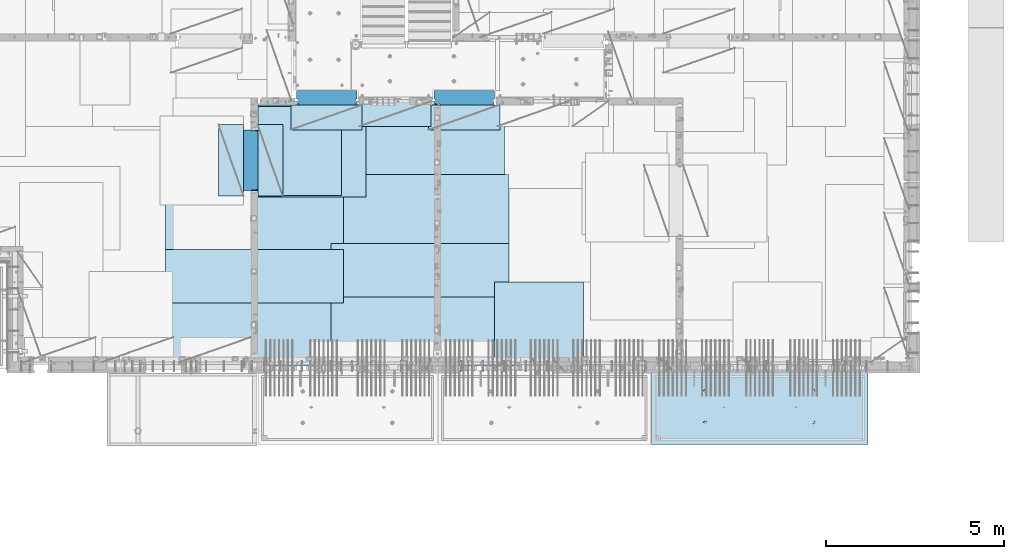
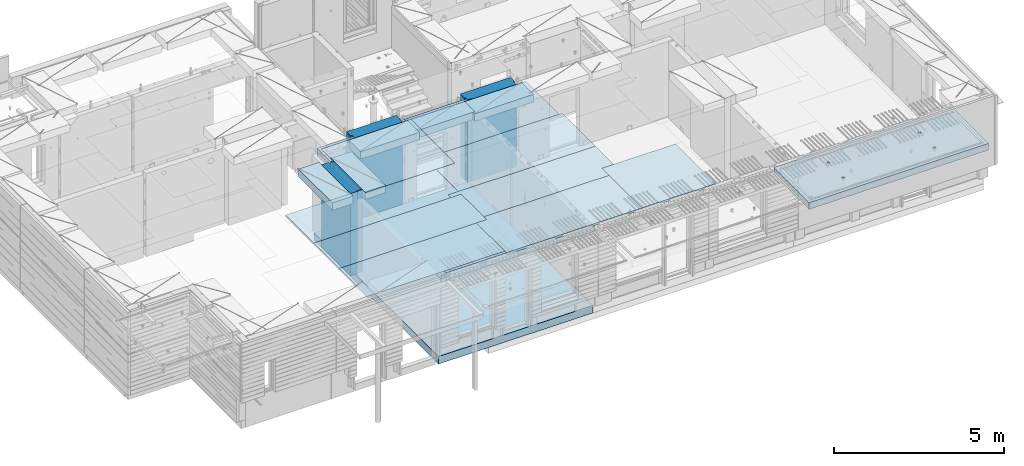
# One storey, part 182 of 325: 18 plates, 3 slabs, 20 elements without a shape of their own.
"""IFC2X3 building model written with IfcOpenShell, lengths in millimetres."""

import ifcopenshell
import ifcopenshell.guid

model = None  # the IFC model being written
_history = None  # IfcOwnerHistory: only IFC2X3 demands one
_inside = {}  # id of a spatial element -> (the spatial element, [elements in it])
_under = {}  # id of a project, library or spatial element -> (it, [spatial elements below it])
_declared = {}  # id of a project -> (the project, [libraries it declares])
_typed = {}  # id of a type object -> (the type object, [elements of that type])
_made_of = {}  # id of a material, layer set ... -> (it, [elements and type objects made of it])


def new_model(schema):
    """Start an empty IFC model of exactly this schema.

    Asked for "IFC4X3", IfcOpenShell would pick the latest addendum, in which some entities
    have other attributes; the version numbers below select the first issue.
    IFC2X3 requires an IfcOwnerHistory on every rooted entity: one is made here for all.
    """
    global model, _history
    if schema == "IFC4X3":
        model = ifcopenshell.file(schema_version=(4, 3, 0, 0))
    else:
        model = ifcopenshell.file(schema=schema)
    _inside.clear()
    _under.clear()
    _declared.clear()
    _typed.clear()
    _made_of.clear()
    _history = None
    if model.schema == "IFC2X3":
        org = make("IfcOrganization", Name="unknown")
        user = make(
            "IfcPersonAndOrganization",
            ThePerson=make("IfcPerson", FamilyName="unknown"),
            TheOrganization=org,
        )
        app = make(
            "IfcApplication",
            ApplicationDeveloper=org,
            Version="unknown",
            ApplicationFullName="unknown",
            ApplicationIdentifier="unknown",
        )
        _history = make(
            "IfcOwnerHistory",
            OwningUser=user,
            OwningApplication=app,
            ChangeAction="ADDED",
            CreationDate=0,
        )
    return model


def make(cls, **values):
    """One entity of the class cls with the attributes given. An attribute that is None is left unset."""
    return model.create_entity(
        cls, **{name: value for name, value in values.items() if value is not None}
    )


def rooted(cls, **values):
    """An entity with a GlobalId (a new one), such as an element, a storey or a relation."""
    return make(cls, GlobalId=ifcopenshell.guid.new(), OwnerHistory=_history, **values)


def si_unit(unit_type, name, prefix=None):
    """IfcSIUnit, for example si_unit("LENGTHUNIT", "METRE", prefix="MILLI")."""
    return make("IfcSIUnit", UnitType=unit_type, Prefix=prefix, Name=name)


def assignment(units):
    """IfcUnitAssignment: the units of a project."""
    return None if units is None else make("IfcUnitAssignment", Units=units)


def point(xyz):
    """IfcCartesianPoint."""
    return None if xyz is None else make("IfcCartesianPoint", Coordinates=xyz)


def direction(xyz):
    """IfcDirection."""
    return None if xyz is None else make("IfcDirection", DirectionRatios=xyz)


def frame(location, z_axis=None, x_axis=None):
    """IfcAxis2Placement3D, a coordinate frame: its origin and axes. An axis left out is left unset."""
    return make(
        "IfcAxis2Placement3D",
        Location=point(location),
        Axis=direction(z_axis),
        RefDirection=direction(x_axis),
    )


def origin_with_axes():
    """The frame at (0, 0, 0) with the z axis (0, 0, 1) and the x axis (1, 0, 0) written out."""
    return frame((0.0, 0.0, 0.0), z_axis=(0.0, 0.0, 1.0), x_axis=(1.0, 0.0, 0.0))


def place(relative_to, where):
    """IfcLocalPlacement: puts the frame where relative to a parent placement (None: the world)."""
    return make(
        "IfcLocalPlacement", PlacementRelTo=relative_to, RelativePlacement=where
    )


def context(
    kind, dimensions, precision=None, world=None, true_north=None, identifier=None
):
    """IfcGeometricRepresentationContext, for example the 3D "Model" context."""
    return make(
        "IfcGeometricRepresentationContext",
        ContextIdentifier=identifier,
        ContextType=kind,
        CoordinateSpaceDimension=dimensions,
        Precision=precision,
        WorldCoordinateSystem=world,
        TrueNorth=true_north,
    )


def subcontext(parent, identifier, kind, view, scale=None):
    """IfcGeometricRepresentationSubContext, for example "Body" below "Model"."""
    return make(
        "IfcGeometricRepresentationSubContext",
        ContextIdentifier=identifier,
        ContextType=kind,
        ParentContext=parent,
        TargetScale=scale,
        TargetView=view,
    )


def project(units=None, contexts=None):
    """IfcProject with its units and contexts."""
    return rooted(
        "IfcProject",
        Name="project",
        RepresentationContexts=contexts,
        UnitsInContext=assignment(units),
    )


def spatial(cls, under=None, at=None, **own):
    """A site, building, storey or space (cls), placed at a placement, below another one or the project."""
    s = rooted(cls, ObjectPlacement=at, **own)
    if under is not None:
        _under.setdefault(under.id(), (under, []))[1].append(s)
    return s


def faces_of(points, faces, orient=None, outer=None):
    """IfcFace entities. A face is a list of loops; a loop is a list of indices into points, from 0.

    orient and outer hold one flag for each loop. By default every Orientation is true, the
    first loop of a face is its IfcFaceOuterBound and the others are IfcFaceBound.
    """
    made = []
    for i, loops in enumerate(faces):
        bounds = []
        for j, loop in enumerate(loops):
            is_outer = j == 0 if outer is None else outer[i][j]
            bounds.append(
                make(
                    "IfcFaceOuterBound" if is_outer else "IfcFaceBound",
                    Bound=make("IfcPolyLoop", Polygon=[points[k] for k in loop]),
                    Orientation=True if orient is None else orient[i][j],
                )
            )
        made.append(make("IfcFace", Bounds=bounds))
    return made


def faceted_brep(points, faces, orient=None, outer=None, voids=None):
    """IfcFacetedBrep: a solid bounded by flat faces; with voids (closed shells), ...WithVoids."""
    shared = [point(p) for p in points]
    hull = make("IfcClosedShell", CfsFaces=faces_of(shared, faces, orient, outer))
    if voids is None:
        return make("IfcFacetedBrep", Outer=hull)
    return make(
        "IfcFacetedBrepWithVoids",
        Outer=hull,
        Voids=[
            make(cls, CfsFaces=faces_of(shared, fs, o, b)) for cls, fs, o, b in voids
        ],
    )


def shape(context_of_items, identifier, shape_type, items):
    """IfcShapeRepresentation: the items that make up one representation, for example the "Body"."""
    return make(
        "IfcShapeRepresentation",
        ContextOfItems=context_of_items,
        RepresentationIdentifier=identifier,
        RepresentationType=shape_type,
        Items=items,
    )


def material(Name=None, Category=None):
    """IfcMaterial."""
    return make("IfcMaterial", Name=Name, Category=Category)


def made_of(thing, what):
    """Note that an element or type object is made of a material, layer set ...; save() writes the relation."""
    if what is not None:
        _made_of.setdefault(what.id(), (what, []))[1].append(thing)
    return thing


def type_object(cls, material=None, **own):
    """A type object (cls), such as IfcWallType, which elements share."""
    return made_of(rooted(cls, **own), material)


def element(
    cls,
    number,
    at=None,
    inside=None,
    cuts=None,
    type_object=None,
    material=None,
    context=None,
    identifier="Body",
    shape_type=None,
    held_by="IfcProductDefinitionShape",
    body=None,
    shapes=None,
    **own,
):
    """One element of the class cls, such as IfcWall. Its Tag is "e" and its number.

    at: its placement. inside: the storey or other place that contains it. cuts: it is an
    opening in that element (IfcRelVoidsElement). A single representation is given by context,
    identifier, shape_type and body (its items); several are given by shapes. held_by: the class
    of the entity that holds the representations. save() writes the other relations.
    """
    e = rooted(cls, Tag="e%d" % number, ObjectPlacement=at, **own)
    if body is not None:
        shapes = [shape(context, identifier, shape_type, body)]
    if shapes is not None:
        e.Representation = make(held_by, Representations=shapes)
    if inside is not None:
        _inside.setdefault(inside.id(), (inside, []))[1].append(e)
    if cuts is not None:
        rooted(
            "IfcRelVoidsElement", RelatingBuildingElement=cuts, RelatedOpeningElement=e
        )
    if type_object is not None:
        _typed.setdefault(type_object.id(), (type_object, []))[1].append(e)
    return made_of(e, material)


def aggregate(whole, parts):
    """IfcRelAggregates: a whole, such as a stair, and the parts it consists of."""
    return rooted("IfcRelAggregates", RelatingObject=whole, RelatedObjects=parts)


def save(model, path):
    """Write the relations noted so far, then the file.

    IfcRelAggregates (storeys below a building ...), IfcRelContainedInSpatialStructure (elements
    in a storey), IfcRelDefinesByType, IfcRelAssociatesMaterial and IfcRelDeclares: one each for
    every whole, place, type object, material and project.
    """
    for whole, parts in _under.values():
        aggregate(whole, parts)
    for where, things in _inside.values():
        rooted(
            "IfcRelContainedInSpatialStructure",
            RelatedElements=things,
            RelatingStructure=where,
        )
    for kind, things in _typed.values():
        rooted("IfcRelDefinesByType", RelatedObjects=things, RelatingType=kind)
    for what, things in _made_of.values():
        rooted("IfcRelAssociatesMaterial", RelatedObjects=things, RelatingMaterial=what)
    for by, libraries in _declared.values():
        rooted("IfcRelDeclares", RelatingContext=by, RelatedDefinitions=libraries)
    model.write(path)


model = new_model("IFC2X3")

# Units and contexts
model_context = context("Model", 3, precision=1e-05, world=origin_with_axes())
body_context = subcontext(model_context, "Body", "Model", "MODEL_VIEW")
ifc_project = project(units=[si_unit("LENGTHUNIT", "METRE", prefix="MILLI"), si_unit("AREAUNIT", "SQUARE_METRE"), si_unit("VOLUMEUNIT", "CUBIC_METRE"), si_unit("MASSUNIT", "GRAM", prefix="KILO"), si_unit("TIMEUNIT", "SECOND"), si_unit("PLANEANGLEUNIT", "RADIAN"), si_unit("SOLIDANGLEUNIT", "STERADIAN"), si_unit("THERMODYNAMICTEMPERATUREUNIT", "DEGREE_CELSIUS"), si_unit("LUMINOUSINTENSITYUNIT", "LUMEN")], contexts=[model_context])

# Site, building, storey
site_placement = place(None, origin_with_axes())
site = spatial("IfcSite", under=ifc_project, at=site_placement, CompositionType="ELEMENT")
building_placement = place(site_placement, origin_with_axes())
building = spatial("IfcBuilding", under=site, at=building_placement, CompositionType="ELEMENT")
storey_placement = place(building_placement, origin_with_axes())
storey = spatial("IfcBuildingStorey", under=building, at=storey_placement, Name="1", CompositionType="ELEMENT", Elevation=0.0)

# Assembly, slab
assembly_1_placement = place(storey_placement, origin_with_axes())
assembly_1 = element("IfcElementAssembly", 1, at=assembly_1_placement, inside=storey, AssemblyPlace="NOTDEFINED", PredefinedType="REINFORCEMENT_UNIT")
ifc_material_1 = material(Name="CONCRETE/C30/37")
slab_type_1 = type_object("IfcSlabType", PredefinedType="NOTDEFINED")
slab_1_placement = place(assembly_1_placement, frame((21810.0, 15180.0, 81595.0), z_axis=(0.0, -1.0, 0.0), x_axis=(-1.0, 3.00000001838171e-08, 0.0)))
slab_1 = element("IfcSlab", 2, at=slab_1_placement, type_object=slab_type_1, material=ifc_material_1, PredefinedType="FLOOR", context=body_context, shape_type="Brep", body=[
    faceted_brep([(1.81898940354586e-12, -135.0, 1.81898940354586e-12), (0.0, -135.0, 7330.0), (0.0, 135.0, 7330.0), (1.81898940354586e-12, 135.0, 1.81898940354586e-12), (5055.0, -135.0, 7330.0), (5055.0, 135.0, 7330.0), (5250.0, -135.0, 7330.0), (5250.0, 135.0, 7330.0), (5250.0, -135.0, 0.0), (5250.0, 135.0, 0.0)], [[[0, 1, 2, 3]], [[1, 4, 5, 2]], [[4, 6, 7, 5]], [[6, 8, 9, 7]], [[8, 0, 3, 9]], [[5, 7, 9, 3, 2]], [[8, 6, 4, 1, 0]]]),
])
aggregate(assembly_1, [slab_1])

assembly_2_placement = place(storey_placement, origin_with_axes())
assembly_2 = element("IfcElementAssembly", 3, at=assembly_2_placement, inside=storey, AssemblyPlace="NOTDEFINED", PredefinedType="REINFORCEMENT_UNIT")
ifc_material_2 = material(Name="CONCRETE/C35/45")
slab_type_2 = type_object("IfcSlabType", PredefinedType="NOTDEFINED")
slab_2_placement = place(assembly_2_placement, frame((33909.9998568133, 7629.99655735226, 84590.0), z_axis=(-1.11800000013248e-06, -0.999999999999375, 0.0), x_axis=(-0.999999999999093, 1.34699999998405e-06, 0.0)))
slab_2 = element("IfcSlab", 4, at=slab_2_placement, type_object=slab_type_2, material=ifc_material_2, PredefinedType="FLOOR", context=body_context, shape_type="Brep", body=[
    faceted_brep([(4605.44993885855, -113.0, 552.448239707288), (4619.38834372919, -113.0, 559.550231553701), (4630.44991833371, -113.0, 570.61183115741), (4637.55187867931, -113.0, 584.55025207851), (4639.99903540509, -113.0, 600.001104562554), (4637.55184376039, -113.0, 615.451951515985), (4630.44985191398, -113.0, 629.39035638662), (4619.38825231027, -113.0, 640.451930991143), (4605.44983138917, -113.0, 647.553891336743), (4589.99897890513, -113.0, 650.001048062522), (4574.54813195169, -113.0, 647.553856417822), (4560.60972708106, -113.0, 640.451864571409), (4549.54815247653, -113.0, 629.390264967699), (4542.44619213093, -113.0, 615.451844046599), (4539.99903540516, -113.0, 600.000991562554), (4542.44622704986, -113.0, 584.550144609124), (4549.54821889627, -113.0, 570.61173973849), (4560.60981849998, -113.0, 559.550165133966), (4574.54823942108, -113.0, 552.448204788368), (4589.99909190512, -113.0, 550.001048062586), (4548.90468317908, -120.0, 570.144182560607), (4541.68970509875, -120.0, 584.304334781456), (4560.14226277649, -120.0, 558.906628360102), (4574.30243130315, -120.0, 551.691682281732), (4589.99909280399, -120.0, 549.205593517132), (4605.69574868622, -120.0, 551.691717756181), (4619.85590090707, -120.0, 558.906695836513), (4631.09345510757, -120.0, 570.14427543392), (4638.30840118594, -120.0, 584.304443960583), (4640.79448995055, -120.0, 600.001105461418), (4638.30836571149, -120.0, 615.697761343653), (4631.09338763116, -120.0, 629.857913564502), (4619.85580803376, -120.0, 641.095467765007), (4605.6956395071, -120.0, 648.310413843377), (4589.99897800626, -120.0, 650.796502607977), (4574.30232212402, -120.0, 648.310378368928), (4560.14216990317, -120.0, 641.095400288596), (4548.90461570267, -120.0, 629.85782069119), (4541.6896696243, -120.0, 615.697652164527), (4539.2035808597, -120.0, 600.000990663691), (0.000819232023786753, -120.0, 2085.00366210938), (6090.0009765625, -120.0, 2085.00366210938), (6090.0009765625, 120.0, 2085.00366210938), (0.000819232023786753, 120.0, 2085.00366210938), (6090.0, -120.0, 1.39971234602854e-09), (6090.0, 120.0, 1.39971234602854e-09), (-7.27595761418343e-12, -120.0, -9.09494701772928e-13), (-7.27595761418343e-12, 120.0, -9.09494701772928e-13), (1515.44893888152, -108.0, 1437.45474794476), (1529.38734375216, -108.0, 1444.55673979117), (1540.44891835668, -108.0, 1455.61833939488), (1547.55087870228, -108.0, 1469.55676031598), (1549.99803542806, -108.0, 1485.00761280002), (1547.55084378336, -108.0, 1500.45845975345), (1540.44885193695, -108.0, 1514.39686462409), (1529.38725233324, -108.0, 1525.45843922861), (1515.44883141214, -108.0, 1532.56039957421), (1499.99797892809, -108.0, 1535.00755629999), (1484.54713197466, -108.0, 1532.56036465529), (1470.60872710403, -108.0, 1525.45837280888), (1459.5471524995, -108.0, 1514.39677320517), (1452.44519215391, -108.0, 1500.45835228407), (1449.99803542813, -108.0, 1485.00749980002), (1452.44522707283, -108.0, 1469.55665284659), (1459.54721891924, -108.0, 1455.61824797596), (1470.60881852295, -108.0, 1444.55667337144), (1484.54723944405, -108.0, 1437.45471302584), (1499.99809192809, -108.0, 1435.00755630005), (1451.1483322995, -120.0, 1469.13526457059), (1448.63439906449, -120.0, 1485.00749825911), (1458.44401483263, -120.0, 1454.8167213853), (1469.80729442553, -120.0, 1443.45346747338), (1484.12585409903, -120.0, 1436.15781730018), (1499.998093469, -120.0, 1433.64391993642), (1515.87032715753, -120.0, 1436.15785317143), (1530.18887034281, -120.0, 1443.45353570456), (1541.55212425473, -120.0, 1454.81681529746), (1548.84777442794, -120.0, 1469.13537497096), (1551.3616717917, -120.0, 1485.00761434093), (1548.84773855669, -120.0, 1500.87984802946), (1541.55205602355, -120.0, 1515.19839121474), (1530.18877643065, -120.0, 1526.56164512666), (1515.87021675716, -120.0, 1533.85729529987), (1499.99797738718, -120.0, 1536.37119266363), (1484.12574369866, -120.0, 1533.85725942862), (1469.80720051337, -120.0, 1526.56157689548), (1458.44394660145, -120.0, 1515.19829730258), (1451.14829642824, -120.0, 1500.87973762909), (1515.44993893152, -113.0, 552.45474794532), (1529.38834380215, -113.0, 559.556739791733), (1540.44991840668, -113.0, 570.618339395443), (1547.55187875228, -113.0, 584.556760316543), (1549.99903547806, -113.0, 600.007612800588), (1547.55184383336, -113.0, 615.458459754018), (1540.44985198694, -113.0, 629.396864624653), (1529.38825238323, -113.0, 640.458439229175), (1515.44983146213, -113.0, 647.560399574775), (1499.99897897809, -113.0, 650.007556300556), (1484.54813202466, -113.0, 647.560364655855), (1470.60972715402, -113.0, 640.458372809442), (1459.5481525495, -113.0, 629.396773205733), (1452.4461922039, -113.0, 615.458352284632), (1449.99903547812, -113.0, 600.007499800588), (1452.44622712283, -113.0, 584.556652847157), (1459.54821896923, -113.0, 570.618247976523), (1470.60981857295, -113.0, 559.556673372), (1484.54823949404, -113.0, 552.4547130264), (1499.99909197809, -113.0, 550.007556300619), (1451.68970517172, -120.0, 584.310843019489), (1449.20358093267, -120.0, 600.007498901724), (1458.90468325205, -120.0, 570.15069079864), (1470.14226284945, -120.0, 558.913136598135), (1484.30243137612, -120.0, 551.698190519764), (1499.99909287695, -120.0, 549.212101755165), (1515.69574875919, -120.0, 551.698225994213), (1529.85590098004, -120.0, 558.913204074546), (1541.09345518054, -120.0, 570.150783671952), (1548.30840125891, -120.0, 584.310952198615), (1550.79449002351, -120.0, 600.007613699451), (1548.30836578447, -120.0, 615.704269581685), (1541.09338770413, -120.0, 629.864421802535), (1529.85580810672, -120.0, 641.10197600304), (1515.69563958006, -120.0, 648.31692208141), (1499.99897807923, -120.0, 650.803010846011), (1484.30232219699, -120.0, 648.316886606961), (1470.14216997614, -120.0, 641.101908526629), (1458.90461577564, -120.0, 629.864328929222), (1451.68966969727, -120.0, 615.704160402559), (4605.44893880856, -108.0, 1437.44823970672), (4619.38734367919, -108.0, 1444.55023155314), (4630.44891828372, -108.0, 1455.61183115685), (4637.55087862931, -108.0, 1469.55025207795), (4639.99803535509, -108.0, 1485.00110456199), (4637.55084371039, -108.0, 1500.45195151542), (4630.44885186398, -108.0, 1514.39035638605), (4619.38725226027, -108.0, 1525.45193099058), (4605.44883133917, -108.0, 1532.55389133618), (4589.99797885512, -108.0, 1535.00104806196), (4574.54713190169, -108.0, 1532.55385641726), (4560.60872703106, -108.0, 1525.45186457084), (4549.54715242653, -108.0, 1514.39026496713), (4542.44519208094, -108.0, 1500.45184404603), (4539.99803535516, -108.0, 1485.00099156199), (4542.44522699986, -108.0, 1469.55014460856), (4549.54721884627, -108.0, 1455.61173973792), (4560.60881844998, -108.0, 1444.5501651334), (4574.54723937108, -108.0, 1437.4482047878), (4589.99809185513, -108.0, 1435.00104806202), (4541.14833222653, -120.0, 1469.12875633256), (4538.63439899152, -120.0, 1485.00099002108), (4548.44401475967, -120.0, 1454.81021314727), (4559.80729435257, -120.0, 1443.44695923535), (4574.12585402606, -120.0, 1436.15130906214), (4589.99809339604, -120.0, 1433.63741169839), (4605.87032708456, -120.0, 1436.1513449334), (4620.18887026985, -120.0, 1443.44702746653), (4631.55212418177, -120.0, 1454.81030705943), (4638.84777435497, -120.0, 1469.12886673293), (4641.36167171873, -120.0, 1485.0011061029), (4638.84773848372, -120.0, 1500.87333979142), (4631.55205595059, -120.0, 1515.19188297671), (4620.18877635769, -120.0, 1526.55513688863), (4605.87021668419, -120.0, 1533.85078706184), (4589.99797731422, -120.0, 1536.36468442559), (4574.12574362569, -120.0, 1533.85075119058), (4559.80720044041, -120.0, 1526.55506865745), (4548.44394652849, -120.0, 1515.19178906455), (4541.14829635528, -120.0, 1500.87322939105)], [[[0, 1, 2, 3, 4, 5, 6, 7, 8, 9, 10, 11, 12, 13, 14, 15, 16, 17, 18, 19]], [[20, 16, 15, 21]], [[22, 17, 16, 20]], [[23, 18, 17, 22]], [[24, 19, 18, 23]], [[25, 0, 19, 24]], [[26, 1, 0, 25]], [[27, 2, 1, 26]], [[28, 3, 2, 27]], [[29, 4, 3, 28]], [[30, 5, 4, 29]], [[31, 6, 5, 30]], [[32, 7, 6, 31]], [[33, 8, 7, 32]], [[34, 9, 8, 33]], [[35, 10, 9, 34]], [[36, 11, 10, 35]], [[37, 12, 11, 36]], [[38, 13, 12, 37]], [[39, 14, 13, 38]], [[21, 15, 14, 39]], [[40, 41, 42, 43]], [[41, 44, 45, 42]], [[44, 46, 47, 45]], [[42, 45, 47, 43]], [[46, 40, 43, 47]], [[48, 49, 50, 51, 52, 53, 54, 55, 56, 57, 58, 59, 60, 61, 62, 63, 64, 65, 66, 67]], [[68, 63, 62, 69]], [[70, 64, 63, 68]], [[71, 65, 64, 70]], [[72, 66, 65, 71]], [[73, 67, 66, 72]], [[74, 48, 67, 73]], [[75, 49, 48, 74]], [[76, 50, 49, 75]], [[77, 51, 50, 76]], [[78, 52, 51, 77]], [[79, 53, 52, 78]], [[80, 54, 53, 79]], [[81, 55, 54, 80]], [[82, 56, 55, 81]], [[83, 57, 56, 82]], [[84, 58, 57, 83]], [[85, 59, 58, 84]], [[86, 60, 59, 85]], [[87, 61, 60, 86]], [[69, 62, 61, 87]], [[88, 89, 90, 91, 92, 93, 94, 95, 96, 97, 98, 99, 100, 101, 102, 103, 104, 105, 106, 107]], [[108, 103, 102, 109]], [[110, 104, 103, 108]], [[111, 105, 104, 110]], [[112, 106, 105, 111]], [[113, 107, 106, 112]], [[114, 88, 107, 113]], [[115, 89, 88, 114]], [[116, 90, 89, 115]], [[117, 91, 90, 116]], [[118, 92, 91, 117]], [[119, 93, 92, 118]], [[120, 94, 93, 119]], [[121, 95, 94, 120]], [[122, 96, 95, 121]], [[123, 97, 96, 122]], [[124, 98, 97, 123]], [[125, 99, 98, 124]], [[126, 100, 99, 125]], [[127, 101, 100, 126]], [[109, 102, 101, 127]], [[128, 129, 130, 131, 132, 133, 134, 135, 136, 137, 138, 139, 140, 141, 142, 143, 144, 145, 146, 147]], [[148, 143, 142, 149]], [[150, 144, 143, 148]], [[151, 145, 144, 150]], [[152, 146, 145, 151]], [[153, 147, 146, 152]], [[154, 128, 147, 153]], [[155, 129, 128, 154]], [[156, 130, 129, 155]], [[157, 131, 130, 156]], [[158, 132, 131, 157]], [[159, 133, 132, 158]], [[160, 134, 133, 159]], [[161, 135, 134, 160]], [[162, 136, 135, 161]], [[163, 137, 136, 162]], [[164, 138, 137, 163]], [[165, 139, 138, 164]], [[166, 140, 139, 165]], [[167, 141, 140, 166]], [[149, 142, 141, 167]], [[44, 41, 40, 46], [37, 36, 35, 34, 33, 32, 31, 30, 29, 28, 27, 26, 25, 24, 23, 22, 20, 21, 39, 38], [166, 165, 164, 163, 162, 161, 160, 159, 158, 157, 156, 155, 154, 153, 152, 151, 150, 148, 149, 167], [126, 125, 124, 123, 122, 121, 120, 119, 118, 117, 116, 115, 114, 113, 112, 111, 110, 108, 109, 127], [86, 85, 84, 83, 82, 81, 80, 79, 78, 77, 76, 75, 74, 73, 72, 71, 70, 68, 69, 87]]]),
])
aggregate(assembly_2, [slab_2])

# Assembly, plate
assembly_3_placement = place(storey_placement, origin_with_axes())
assembly_3 = element("IfcElementAssembly", 5, at=assembly_3_placement, inside=storey, Name="Steel Assembly", AssemblyPlace="NOTDEFINED", PredefinedType="NOTDEFINED")
ifc_material_3 = material()
plate_type_1 = type_object("IfcPlateType", PredefinedType="NOTDEFINED")
plate_1_placement = place(assembly_3_placement, frame((25910.0, 7750.0, 84695.1), z_axis=(-1.0, 3.00000001838171e-08, 0.0), x_axis=(0.0, 1.0, 0.0)))
plate_1 = element("IfcPlate", 6, at=plate_1_placement, type_object=plate_type_1, material=ifc_material_3, Name="1/2", context=body_context, shape_type="Brep", body=[
    faceted_brep([(0.0, -35.0, 0.0), (0.0, -35.0, 2500.0), (0.0, 35.0, 2500.0), (0.0, 35.0, 0.0), (2349.99951171875, -35.0, 2500.0), (2349.99951171875, 35.0, 2500.0), (2350.0, -35.0, 0.0), (2350.0, 35.0, 0.0)], [[[0, 1, 2, 3]], [[1, 4, 5, 2]], [[4, 6, 7, 5]], [[6, 0, 3, 7]], [[5, 7, 3, 2]], [[6, 4, 1, 0]]]),
])
aggregate(assembly_3, [plate_1])

assembly_4_placement = place(storey_placement, origin_with_axes())
assembly_4 = element("IfcElementAssembly", 7, at=assembly_4_placement, inside=storey, Name="Steel Assembly", AssemblyPlace="NOTDEFINED", PredefinedType="NOTDEFINED")
plate_2_placement = place(assembly_4_placement, frame((16759.9995320312, 12530.0000289158, 84695.1), z_axis=(0.0, 1.0, 0.0), x_axis=(1.0, 0.0, 0.0)))
plate_2 = element("IfcPlate", 8, at=plate_2_placement, type_object=plate_type_1, material=ifc_material_3, Name="1/2", context=body_context, shape_type="Brep", body=[
    faceted_brep([(0.0, -35.0, 0.0), (0.0, -35.0, 2500.0), (0.0, 35.0, 2500.0), (0.0, 35.0, 0.0), (2349.99951171875, -35.0, 2500.0), (2349.99951171875, 35.0, 2500.0), (2350.0, -35.0, 0.0), (2350.0, 35.0, 0.0)], [[[0, 1, 2, 3]], [[1, 4, 5, 2]], [[4, 6, 7, 5]], [[6, 0, 3, 7]], [[5, 7, 3, 2]], [[6, 4, 1, 0]]]),
])
aggregate(assembly_4, [plate_2])

assembly_5_placement = place(storey_placement, origin_with_axes())
assembly_5 = element("IfcElementAssembly", 9, at=assembly_5_placement, inside=storey, Name="Steel Assembly", AssemblyPlace="NOTDEFINED", PredefinedType="NOTDEFINED")
plate_3_placement = place(assembly_5_placement, frame((23810.0, 10780.0, 84695.1), z_axis=(-1.0, 3.00000001838171e-08, 0.0), x_axis=(0.0, 1.0, 0.0)))
plate_3 = element("IfcPlate", 10, at=plate_3_placement, type_object=plate_type_1, material=ifc_material_3, context=body_context, shape_type="Brep", body=[
    faceted_brep([(0.0, -35.0, 0.0), (0.0, -35.0, 5000.0), (0.0, 35.0, 5000.0), (0.0, 35.0, 0.0), (2349.99951171875, -35.0, 5000.0), (2349.99951171875, 35.0, 5000.0), (2350.0, -35.0, 0.0), (2350.0, 35.0, 0.0)], [[[0, 1, 2, 3]], [[1, 4, 5, 2]], [[4, 6, 7, 5]], [[6, 0, 3, 7]], [[5, 7, 3, 2]], [[6, 4, 1, 0]]]),
])
aggregate(assembly_5, [plate_3])

assembly_6_placement = place(storey_placement, origin_with_axes())
assembly_6 = element("IfcElementAssembly", 11, at=assembly_6_placement, inside=storey, Name="Steel Assembly", AssemblyPlace="NOTDEFINED", PredefinedType="NOTDEFINED")
plate_4_placement = place(assembly_6_placement, frame((23710.0, 12730.0, 84695.1), z_axis=(-1.0, 3.00000001838171e-08, 0.0), x_axis=(0.0, 1.0, 0.0)))
plate_4 = element("IfcPlate", 12, at=plate_4_placement, type_object=plate_type_1, material=ifc_material_3, context=body_context, shape_type="Brep", body=[
    faceted_brep([(0.0, -35.0, 0.0), (0.0, -35.0, 5000.0), (0.0, 35.0, 5000.0), (0.0, 35.0, 0.0), (2349.99951171875, -35.0, 5000.0), (2349.99951171875, 35.0, 5000.0), (2350.0, -35.0, 0.0), (2350.0, 35.0, 0.0)], [[[0, 1, 2, 3]], [[1, 4, 5, 2]], [[4, 6, 7, 5]], [[6, 0, 3, 7]], [[5, 7, 3, 2]], [[6, 4, 1, 0]]]),
])
aggregate(assembly_6, [plate_4])

assembly_7_placement = place(storey_placement, origin_with_axes())
assembly_7 = element("IfcElementAssembly", 13, at=assembly_7_placement, inside=storey, Name="Steel Assembly", AssemblyPlace="NOTDEFINED", PredefinedType="NOTDEFINED")
plate_5_placement = place(assembly_7_placement, frame((23810.0, 7750.0, 84695.1), z_axis=(-1.0, 3.00000001838171e-08, 0.0), x_axis=(0.0, 1.0, 0.0)))
plate_5 = element("IfcPlate", 14, at=plate_5_placement, type_object=plate_type_1, material=ifc_material_3, context=body_context, shape_type="Brep", body=[
    faceted_brep([(0.0, -35.0, 0.0), (0.0, -35.0, 5000.0), (0.0, 35.0, 5000.0), (0.0, 35.0, 0.0), (2349.99951171875, -35.0, 5000.0), (2349.99951171875, 35.0, 5000.0), (2350.0, -35.0, 0.0), (2350.0, 35.0, 0.0)], [[[0, 1, 2, 3]], [[1, 4, 5, 2]], [[4, 6, 7, 5]], [[6, 0, 3, 7]], [[5, 7, 3, 2]], [[6, 4, 1, 0]]]),
])
aggregate(assembly_7, [plate_5])

assembly_8_placement = place(storey_placement, origin_with_axes())
assembly_8 = element("IfcElementAssembly", 15, at=assembly_8_placement, inside=storey, Name="Steel Assembly", AssemblyPlace="NOTDEFINED", PredefinedType="NOTDEFINED")
plate_6_placement = place(assembly_8_placement, frame((19160.0, 10325.0, 84695.1), z_axis=(-1.0, 3.00000001838171e-08, 0.0), x_axis=(0.0, 1.0, 0.0)))
plate_6 = element("IfcPlate", 16, at=plate_6_placement, type_object=plate_type_1, material=ifc_material_3, context=body_context, shape_type="Brep", body=[
    faceted_brep([(0.0, -35.0, 0.0), (0.0, -35.0, 5000.0), (0.0, 35.0, 5000.0), (0.0, 35.0, 0.0), (2349.99951171875, -35.0, 5000.0), (2349.99951171875, 35.0, 5000.0), (2350.0, -35.0, 0.0), (2350.0, 35.0, 0.0)], [[[0, 1, 2, 3]], [[1, 4, 5, 2]], [[4, 6, 7, 5]], [[6, 0, 3, 7]], [[5, 7, 3, 2]], [[6, 4, 1, 0]]]),
])
aggregate(assembly_8, [plate_6])

assembly_9_placement = place(storey_placement, origin_with_axes())
assembly_9 = element("IfcElementAssembly", 17, at=assembly_9_placement, inside=storey, Name="Steel Assembly", AssemblyPlace="NOTDEFINED", PredefinedType="NOTDEFINED")
plate_7_placement = place(assembly_9_placement, frame((19160.0, 7850.0, 84695.1), z_axis=(-1.0, 3.00000001838171e-08, 0.0), x_axis=(0.0, 1.0, 0.0)))
plate_7 = element("IfcPlate", 18, at=plate_7_placement, type_object=plate_type_1, material=ifc_material_3, context=body_context, shape_type="Brep", body=[
    faceted_brep([(0.0, -35.0, 0.0), (0.0, -35.0, 5000.0), (0.0, 35.0, 5000.0), (0.0, 35.0, 0.0), (2349.99951171875, -35.0, 5000.0), (2349.99951171875, 35.0, 5000.0), (2350.0, -35.0, 0.0), (2350.0, 35.0, 0.0)], [[[0, 1, 2, 3]], [[1, 4, 5, 2]], [[4, 6, 7, 5]], [[6, 0, 3, 7]], [[5, 7, 3, 2]], [[6, 4, 1, 0]]]),
])
aggregate(assembly_9, [plate_7])

assembly_10_placement = place(storey_placement, origin_with_axes())
assembly_10 = element("IfcElementAssembly", 19, at=assembly_10_placement, inside=storey, Name="Steel Assembly", AssemblyPlace="NOTDEFINED", PredefinedType="NOTDEFINED")
plate_type_2 = type_object("IfcPlateType", PredefinedType="NOTDEFINED")
plate_8_placement = place(assembly_10_placement, frame((18810.0, 11180.0000122641, 84695.1000003815), z_axis=(1.0, 0.0, 0.0), x_axis=(0.0, -1.0, 0.0)))
plate_8 = element("IfcPlate", 20, at=plate_8_placement, type_object=plate_type_2, material=ifc_material_3, context=body_context, shape_type="Brep", body=[
    faceted_brep([(0.0, -35.0, 0.0), (0.0, -35.0, 5000.0), (0.0, 35.0, 5000.0), (0.0, 35.0, 0.0), (1499.99951171875, -35.0, 5000.0), (1499.99951171875, 35.0, 5000.0), (1500.0, -35.0, 0.0), (1500.0, 35.0, 0.0)], [[[0, 1, 2, 3]], [[1, 4, 5, 2]], [[4, 6, 7, 5]], [[6, 0, 3, 7]], [[5, 7, 3, 2]], [[6, 4, 1, 0]]]),
])
aggregate(assembly_10, [plate_8])

assembly_11_placement = place(storey_placement, origin_with_axes())
assembly_11 = element("IfcElementAssembly", 21, at=assembly_11_placement, inside=storey, Name="Steel Assembly", AssemblyPlace="NOTDEFINED", PredefinedType="NOTDEFINED")
plate_9_placement = place(assembly_11_placement, frame((14160.0, 11015.0000122641, 84695.1000003815), z_axis=(1.0, 0.0, 0.0), x_axis=(0.0, -1.0, 0.0)))
plate_9 = element("IfcPlate", 22, at=plate_9_placement, type_object=plate_type_2, material=ifc_material_3, context=body_context, shape_type="Brep", body=[
    faceted_brep([(0.0, -35.0, 0.0), (0.0, -35.0, 5000.0), (0.0, 35.0, 5000.0), (0.0, 35.0, 0.0), (1499.99951171875, -35.0, 5000.0), (1499.99951171875, 35.0, 5000.0), (1500.0, -35.0, 0.0), (1500.0, 35.0, 0.0)], [[[0, 1, 2, 3]], [[1, 4, 5, 2]], [[4, 6, 7, 5]], [[6, 0, 3, 7]], [[5, 7, 3, 2]], [[6, 4, 1, 0]]]),
])
aggregate(assembly_11, [plate_9])

assembly_12_placement = place(storey_placement, origin_with_axes())
assembly_12 = element("IfcElementAssembly", 23, at=assembly_12_placement, inside=storey, Name="Steel Assembly", AssemblyPlace="NOTDEFINED", PredefinedType="NOTDEFINED")
plate_type_3 = type_object("IfcPlateType", PredefinedType="NOTDEFINED")
plate_10_placement = place(assembly_12_placement, frame((16759.9998779297, 14525.0, 84595.3), z_axis=(1.0, 0.0, 0.0), x_axis=(0.0, -1.0, 0.0)))
plate_10 = element("IfcPlate", 24, at=plate_10_placement, type_object=plate_type_3, material=ifc_material_3, Name="RE1", context=body_context, shape_type="Brep", body=[
    faceted_brep([(1.81898940354586e-12, -135.0, 1.81898940354586e-12), (0.0, -135.0, 699.999999999996), (0.0, 135.0, 699.999999999996), (1.81898940354586e-12, 135.0, 1.81898940354586e-12), (1999.99951171875, -135.0, 699.999999999993), (1999.99951171875, 135.0, 699.999999999993), (2000.0, -135.0, -3.63797880709171e-12), (2000.0, 135.0, -3.63797880709171e-12)], [[[0, 1, 2, 3]], [[1, 4, 5, 2]], [[4, 6, 7, 5]], [[6, 0, 3, 7]], [[5, 7, 3, 2]], [[6, 4, 1, 0]]]),
])
aggregate(assembly_12, [plate_10])

assembly_13_placement = place(storey_placement, origin_with_axes())
assembly_13 = element("IfcElementAssembly", 25, at=assembly_13_placement, inside=storey, Name="Steel Assembly", AssemblyPlace="NOTDEFINED", PredefinedType="NOTDEFINED")
plate_11_placement = place(assembly_13_placement, frame((16359.7701220703, 12525.0, 84595.3), z_axis=(-1.0, 3.00000001838171e-08, 0.0), x_axis=(0.0, 1.0, 0.0)))
plate_11 = element("IfcPlate", 26, at=plate_11_placement, type_object=plate_type_3, material=ifc_material_3, Name="RE1", context=body_context, shape_type="Brep", body=[
    faceted_brep([(1.81898940354586e-12, -135.0, 1.81898940354586e-12), (0.0, -135.0, 699.999999999996), (0.0, 135.0, 699.999999999996), (1.81898940354586e-12, 135.0, 1.81898940354586e-12), (1999.99951171875, -135.0, 699.999999999993), (1999.99951171875, 135.0, 699.999999999993), (2000.0, -135.0, -3.63797880709171e-12), (2000.0, 135.0, -3.63797880709171e-12)], [[[0, 1, 2, 3]], [[1, 4, 5, 2]], [[4, 6, 7, 5]], [[6, 0, 3, 7]], [[5, 7, 3, 2]], [[6, 4, 1, 0]]]),
])
aggregate(assembly_13, [plate_11])

assembly_14_placement = place(storey_placement, origin_with_axes())
assembly_14 = element("IfcElementAssembly", 27, at=assembly_14_placement, inside=storey, Name="Steel Assembly", AssemblyPlace="NOTDEFINED", PredefinedType="NOTDEFINED")
plate_12_placement = place(assembly_14_placement, frame((21624.9991457614, 15179.9998963664, 84595.3), z_axis=(0.0, -1.0, 0.0), x_axis=(-1.0, 3.00000001838171e-08, 0.0)))
plate_12 = element("IfcPlate", 28, at=plate_12_placement, type_object=plate_type_3, material=ifc_material_3, Name="RE1", context=body_context, shape_type="Brep", body=[
    faceted_brep([(1.81898940354586e-12, -135.0, 1.81898940354586e-12), (0.0, -135.0, 699.999999999996), (0.0, 135.0, 699.999999999996), (1.81898940354586e-12, 135.0, 1.81898940354586e-12), (1999.99951171875, -135.0, 699.999999999993), (1999.99951171875, 135.0, 699.999999999993), (2000.0, -135.0, -3.63797880709171e-12), (2000.0, 135.0, -3.63797880709171e-12)], [[[0, 1, 2, 3]], [[1, 4, 5, 2]], [[4, 6, 7, 5]], [[6, 0, 3, 7]], [[5, 7, 3, 2]], [[6, 4, 1, 0]]]),
])
aggregate(assembly_14, [plate_12])

assembly_15_placement = place(storey_placement, origin_with_axes())
assembly_15 = element("IfcElementAssembly", 29, at=assembly_15_placement, inside=storey, Name="Steel Assembly", AssemblyPlace="NOTDEFINED", PredefinedType="NOTDEFINED")
plate_13_placement = place(assembly_15_placement, frame((23559.9991457614, 15079.9998963664, 84595.3), z_axis=(0.0, -1.0, 0.0), x_axis=(-1.0, 3.00000001838171e-08, 0.0)))
plate_13 = element("IfcPlate", 30, at=plate_13_placement, type_object=plate_type_3, material=ifc_material_3, Name="RE1", context=body_context, shape_type="Brep", body=[
    faceted_brep([(1.81898940354586e-12, -135.0, 1.81898940354586e-12), (0.0, -135.0, 699.999999999996), (0.0, 135.0, 699.999999999996), (1.81898940354586e-12, 135.0, 1.81898940354586e-12), (1999.99951171875, -135.0, 699.999999999993), (1999.99951171875, 135.0, 699.999999999993), (2000.0, -135.0, -3.63797880709171e-12), (2000.0, 135.0, -3.63797880709171e-12)], [[[0, 1, 2, 3]], [[1, 4, 5, 2]], [[4, 6, 7, 5]], [[6, 0, 3, 7]], [[5, 7, 3, 2]], [[6, 4, 1, 0]]]),
])
aggregate(assembly_15, [plate_13])

assembly_16_placement = place(storey_placement, origin_with_axes())
assembly_16 = element("IfcElementAssembly", 31, at=assembly_16_placement, inside=storey, Name="Steel Assembly", AssemblyPlace="NOTDEFINED", PredefinedType="NOTDEFINED")
plate_14_placement = place(assembly_16_placement, frame((19689.9991457614, 15079.9998963664, 84595.3), z_axis=(0.0, -1.0, 0.0), x_axis=(-1.0, 3.00000001838171e-08, 0.0)))
plate_14 = element("IfcPlate", 32, at=plate_14_placement, type_object=plate_type_3, material=ifc_material_3, Name="RE1", context=body_context, shape_type="Brep", body=[
    faceted_brep([(1.81898940354586e-12, -135.0, 1.81898940354586e-12), (0.0, -135.0, 699.999999999996), (0.0, 135.0, 699.999999999996), (1.81898940354586e-12, 135.0, 1.81898940354586e-12), (1999.99951171875, -135.0, 699.999999999993), (1999.99951171875, 135.0, 699.999999999993), (2000.0, -135.0, -3.63797880709171e-12), (2000.0, 135.0, -3.63797880709171e-12)], [[[0, 1, 2, 3]], [[1, 4, 5, 2]], [[4, 6, 7, 5]], [[6, 0, 3, 7]], [[5, 7, 3, 2]], [[6, 4, 1, 0]]]),
])
aggregate(assembly_16, [plate_14])

# Assembly, plate, slab
assembly_17_placement = place(storey_placement, origin_with_axes())
assembly_17 = element("IfcElementAssembly", 33, at=assembly_17_placement, inside=storey, AssemblyPlace="NOTDEFINED", PredefinedType="REINFORCEMENT_UNIT")
plate_type_4 = type_object("IfcPlateType", PredefinedType="NOTDEFINED")
plate_15_placement = place(assembly_17_placement, frame((16760.0002457424, 12487.9997681111, 84725.45), z_axis=(0.0, 1.0, 0.0), x_axis=(1.0, 0.0, 0.0)))
plate_15 = element("IfcPlate", 34, at=plate_15_placement, type_object=plate_type_4, material=ifc_material_3, context=body_context, shape_type="Brep", body=[
    faceted_brep([(0.0, -5.0, 0.0), (0.0, -5.0, 2592.0), (0.0, 5.0, 2592.0), (0.0, 5.0, 0.0), (3041.99975585938, -5.0, 2592.0), (3041.99975585938, 5.0, 2592.0), (3041.99975585938, -5.0, 0.0), (3041.99975585938, 5.0, 0.0)], [[[0, 1, 2, 3]], [[1, 4, 5, 2]], [[4, 6, 7, 5]], [[6, 0, 3, 7]], [[5, 7, 3, 2]], [[6, 4, 1, 0]]]),
])
slab_type_3 = type_object("IfcSlabType", PredefinedType="NOTDEFINED")
slab_3_placement = place(assembly_17_placement, frame((21810.0, 15180.0, 84595.0), z_axis=(0.0, -1.0, 0.0), x_axis=(-1.0, 3.00000001838171e-08, 0.0)))
slab_3 = element("IfcSlab", 35, at=slab_3_placement, type_object=slab_type_3, material=ifc_material_1, PredefinedType="FLOOR", context=body_context, shape_type="Brep", body=[
    faceted_brep([(2300.00087620694, -135.0, -2.78342304227408e-06), (2300.00087620694, 135.0, 0.0), (2300.00087620694, 135.0, 100.000233727807), (2300.00087620694, -135.0, 100.000233727807), (3920.000509996, 135.000000000015, 100.000233727807), (3920.000509996, -135.0, 100.000233727807), (3920.00085449219, -135.0, 0.0), (3920.00085449219, 135.0, 0.0), (5150.0, 135.0, 0.0), (5150.0, -135.0, 0.0), (5150.0, 135.0, 804.999923541527), (5150.0, -135.0, 804.999923541527), (5049.99975425761, 135.0, 804.999923541527), (5049.99975425761, -135.0, 804.999923541527), (5049.99975425761, 135.0, 2504.99992354153), (5049.99975425761, -135.0, 2504.99992354153), (5150.0, 135.0, 2504.99992354153), (5150.0, -135.0, 2504.99992354153), (5150.0, 135.0, 7330.0), (5150.0, -135.0, 7330.0), (5055.0, -135.0, 7330.0), (5055.0, 135.0, 7330.0), (5055.0, -135.0, 7430.0), (5055.0, 135.0, 7430.0), (0.0, -135.0, 7430.0), (0.0, 135.0, 7430.0), (70.0000000000036, -135.0, -8.47121555125341e-08), (3.63797880709171e-12, -135.0, 100.0), (70.0000000000036, -135.000000000015, 100.0), (70.0000000000036, 135.0, 0.0), (70.0000000000036, 135.0, 100.0), (0.0, 135.0, 100.0)], [[[0, 1, 2, 3]], [[3, 2, 4, 5]], [[6, 5, 4, 7]], [[8, 9, 6, 7]], [[9, 8, 10, 11]], [[11, 10, 12, 13]], [[13, 12, 14, 15]], [[15, 14, 16, 17]], [[18, 19, 17, 16]], [[20, 19, 18, 21]], [[22, 20, 21, 23]], [[24, 22, 23, 25]], [[26, 0, 3, 5, 6, 9, 11, 13, 15, 17, 19, 20, 22, 24, 27, 28]], [[1, 0, 26, 29]], [[25, 23, 21, 18, 16, 14, 12, 10, 8, 7, 4, 2, 1, 29, 30, 31]], [[26, 28, 30, 29]], [[27, 31, 30, 28]], [[24, 25, 31, 27]]]),
])
aggregate(assembly_17, [plate_15, slab_3])

# Assembly, plate
assembly_18_placement = place(storey_placement, origin_with_axes())
assembly_18 = element("IfcElementAssembly", 36, at=assembly_18_placement, inside=storey, Name="Steel Assembly", AssemblyPlace="NOTDEFINED", PredefinedType="NOTDEFINED")
ifc_material_4 = material()
plate_type_5 = type_object("IfcPlateType", PredefinedType="NOTDEFINED")
plate_16_placement = place(assembly_18_placement, frame((17840.0, 15080.0, 83255.6000003815), z_axis=(0.0, 1.0, 0.0), x_axis=(1.0, 0.0, 0.0)))
plate_16 = element("IfcPlate", 37, at=plate_16_placement, type_object=plate_type_5, material=ifc_material_4, context=body_context, shape_type="Brep", body=[
    faceted_brep([(49.9991463160914, -1475.0, 156.999999814216), (49.9991455078125, -1216.89999961853, 156.999999999998), (49.9994900039455, -1216.89999961853, -0.000233727812883444), (49.9994832763732, -1475.0, 0.0), (0.0, -1475.0, 170.000000230655), (-0.00085392879191204, -1216.89999961853, 170.000000368096), (0.0, -1475.0, 400.0), (1699.99914550781, -1475.0, 400.0), (1699.99914550781, 1475.0, 400.0), (0.0, 1475.0, 400.0), (1699.99914550781, -1475.0, 169.999999999998), (1699.99914550781, 1475.0, 169.999999999998), (1669.99914550781, 1475.0, 156.999999999998), (1669.99914550781, 1475.0, 3.63797880709171e-12), (49.9994900039455, 1475.0, 0.0), (49.9991455078125, 1475.0, 156.999999999998), (0.0, 1475.0, 170.000000368096), (1669.99914550781, -1475.0, 156.999999999998), (1669.99914550781, -1475.0, 3.63797880709171e-12)], [[[0, 1, 2, 3]], [[4, 5, 1, 0]], [[6, 7, 8, 9]], [[8, 7, 10, 11]], [[9, 8, 11, 12, 13, 14, 15, 16]], [[10, 17, 12, 11]], [[18, 13, 12, 17]], [[14, 13, 18, 3, 2]], [[14, 2, 1, 15]], [[15, 1, 5, 16]], [[6, 9, 16, 5, 4]], [[18, 17, 10, 7, 6, 4, 0, 3]]]),
])
aggregate(assembly_18, [plate_16])

assembly_19_placement = place(storey_placement, origin_with_axes())
assembly_19 = element("IfcElementAssembly", 38, at=assembly_19_placement, inside=storey, Name="Steel Assembly", AssemblyPlace="NOTDEFINED", PredefinedType="NOTDEFINED")
plate_17_placement = place(assembly_19_placement, frame((21710.0, 15080.0, 83255.6000003815), z_axis=(0.0, 1.0, 0.0), x_axis=(1.0, 0.0, 0.0)))
plate_17 = element("IfcPlate", 39, at=plate_17_placement, type_object=plate_type_5, material=ifc_material_4, context=body_context, shape_type="Brep", body=[
    faceted_brep([(30.0, -1475.0, 29.9998239177003), (30.0, 1475.0, 29.9998239177003), (157.0, 1475.0, 29.9998239177003), (157.0, -1475.0, 29.9998239177003), (169.999923697669, -1475.0, 0.0), (169.999923697669, 1475.0, 0.0), (0.0, -1475.0, 170.000000230655), (0.0, 1475.0, 170.000000368096), (30.0, 1475.0, 156.999999999998), (30.0, -1475.0, 156.999999999998), (0.0, -1475.0, 400.0), (0.0, 1475.0, 400.0), (1699.99914550781, -1475.0, 400.0), (1699.99914550781, 1475.0, 400.0), (1699.99914550781, -1475.0, 169.999999999998), (1699.99914550781, 1475.0, 169.999999999998), (1669.99914550781, -1475.0, 156.999999999998), (1669.99914550781, 1475.0, 156.999999999998), (1669.99914550781, -1475.0, 3.63797880709171e-12), (1669.99914550781, 1475.0, 3.63797880709171e-12)], [[[0, 1, 2, 3]], [[4, 3, 2, 5]], [[6, 7, 8, 9]], [[10, 11, 7, 6]], [[10, 12, 13, 11]], [[13, 12, 14, 15]], [[14, 16, 17, 15]], [[18, 19, 17, 16]], [[19, 18, 4, 5]], [[1, 8, 7, 11, 13, 15, 17, 19, 5, 2]], [[9, 8, 1, 0]], [[18, 16, 14, 12, 10, 6, 9, 0, 3, 4]]]),
])
aggregate(assembly_19, [plate_17])

assembly_20_placement = place(storey_placement, origin_with_axes())
assembly_20 = element("IfcElementAssembly", 40, at=assembly_20_placement, inside=storey, Name="Steel Assembly", AssemblyPlace="NOTDEFINED", PredefinedType="NOTDEFINED")
plate_18_placement = place(assembly_20_placement, frame((16760.0, 12675.0, 83255.6000003815), z_axis=(-0.999999990476206, -0.000138013000065496, 0.0), x_axis=(-0.000138013000066464, 0.999999990476206, 0.0)))
plate_18 = element("IfcPlate", 41, at=plate_18_placement, type_object=plate_type_5, material=ifc_material_4, context=body_context, shape_type="Brep", body=[
    faceted_brep([(0.0234607562470046, -1475.0, 169.989834633274), (0.0234607562470046, 1475.0, 169.989834633274), (30.0, 1475.0, 156.999999999998), (30.0, -1475.0, 156.999999999998), (29.9999998430139, -1475.0, 0.0), (29.9999998430139, 1475.0, 0.0), (0.0552374608814716, -1475.0, 400.234619140623), (1700.05529785156, -1475.0, 399.999999999998), (1700.05529785156, 1475.0, 399.999999999998), (0.0552374608814716, 1475.0, 400.234619140623), (1700.0235408123, -1475.0, 169.775517151291), (1700.0235408123, 1475.0, 169.775517151291), (1670.00014467176, -1475.0, 156.765378823566), (1670.00014467176, 1475.0, 156.765378823566), (1670.00014467148, -1475.0, 1.13504938781261e-09), (1670.00014467148, 1475.0, 1.13504938781261e-09)], [[[0, 1, 2, 3]], [[4, 3, 2, 5]], [[6, 7, 8, 9]], [[8, 7, 10, 11]], [[12, 13, 11, 10]], [[14, 15, 13, 12]], [[15, 14, 4, 5]], [[1, 9, 8, 11, 13, 15, 5, 2]], [[6, 9, 1, 0]], [[14, 12, 10, 7, 6, 0, 3, 4]]]),
])
aggregate(assembly_20, [plate_18])

save(model, "model.ifc")
